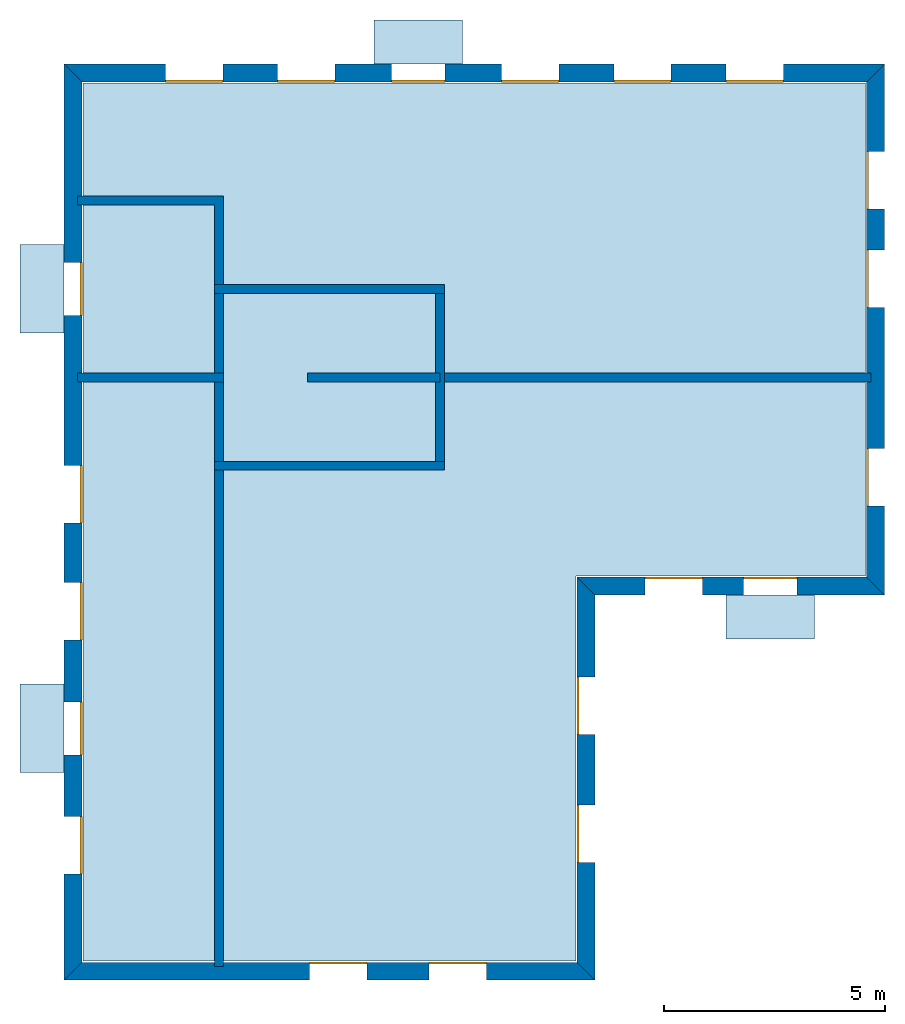
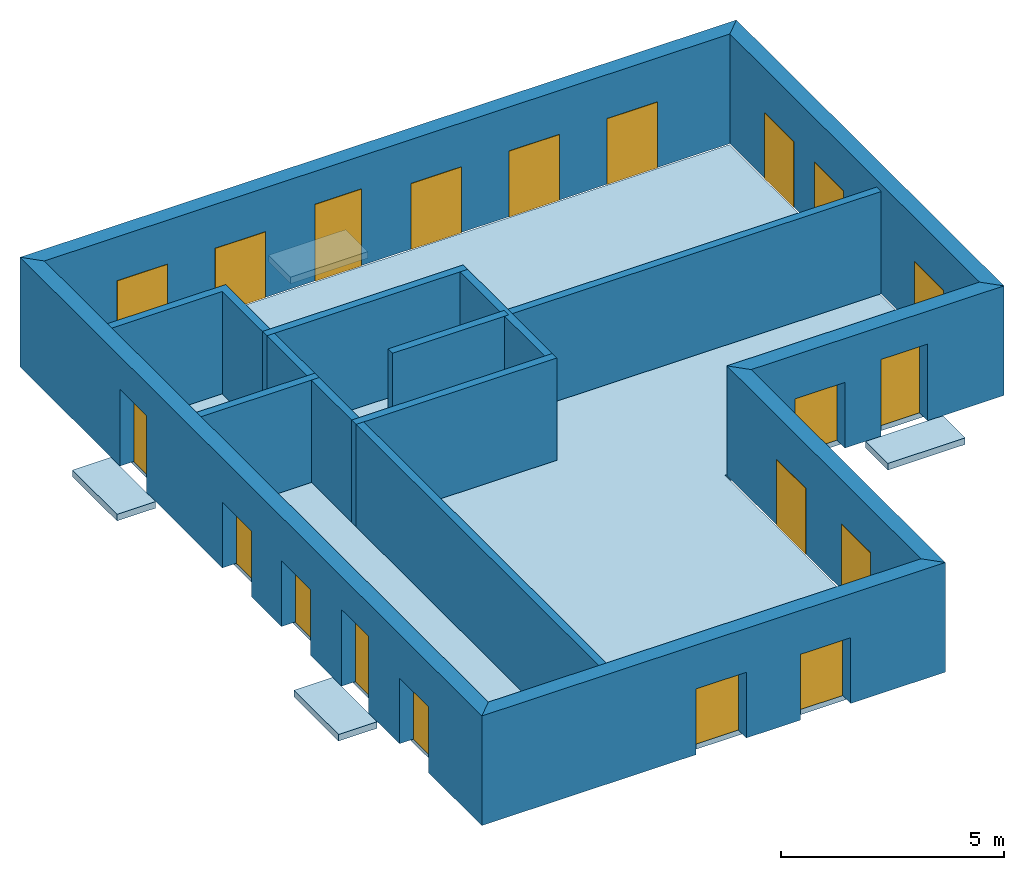
# One storey: 20 windows, 15 walls, 5 slabs, 20 openings.
"""IFC4 building model written with IfcOpenShell, lengths in metres."""

from ifc_helpers import new_model, si_unit, frame, origin_with_axes, place, context, subcontext, project, spatial, line, indexed_curve, outline, extrude, element, fill, save


model = new_model("IFC4")

# Units and contexts
model_context = context("Model", 3, precision=1e-05, world=origin_with_axes())
body_context = subcontext(model_context, "Body", "Model", "MODEL_VIEW")
ifc_project = project(units=[si_unit("VOLUMEUNIT", "CUBIC_METRE"), si_unit("LENGTHUNIT", "METRE"), si_unit("AREAUNIT", "SQUARE_METRE")], contexts=[model_context])

# Site, building, storey
site = spatial("IfcSite", under=ifc_project)
building = spatial("IfcBuilding", under=site, Name="Building 1")
storey_placement = place(None, frame((0.0, 0.0, 4.0), z_axis=(0.0, 0.0, 1.0), x_axis=(1.0, 0.0, 0.0)))
storey = spatial("IfcBuildingStorey", under=building, at=storey_placement, Name="02 Storey")

# Slabs
slab_1_placement = place(storey_placement, origin_with_axes())
element("IfcSlab", 1, at=slab_1_placement, inside=storey, Name="Slab", context=body_context, shape_type="SweptSolid", body=[
    extrude(outline(indexed_curve([(15.563354, 14.685575), (22.109464, 14.685575), (22.109464, 25.825575), (4.423354, 25.825575), (4.423354, 5.9782), (15.563354, 5.9782)], segments=[line(1, 2), line(2, 3), line(3, 4), line(4, 5), line(5, 6)])), origin_with_axes(), (0.0, 0.0, -1.0), 0.2),
])
slab_2_placement = place(storey_placement, origin_with_axes())
element("IfcSlab", 2, at=slab_2_placement, inside=storey, Name="Balcony", context=body_context, shape_type="SweptSolid", body=[
    extrude(outline(indexed_curve([(20.9574273333333, 14.255575), (20.9574273333333, 13.255575), (18.9574273333333, 13.255575), (18.9574273333333, 14.255575)], segments=[line(1, 2), line(2, 3), line(3, 4)])), origin_with_axes(), (0.0, 0.0, -1.0), 0.18),
])
slab_3_placement = place(storey_placement, origin_with_axes())
element("IfcSlab", 3, at=slab_3_placement, inside=storey, Name="Balcony", context=body_context, shape_type="SweptSolid", body=[
    extrude(outline(indexed_curve([(10.9988297142857, 26.255575), (10.9988297142857, 27.255575), (12.9988297142857, 27.255575), (12.9988297142857, 26.255575)], segments=[line(1, 2), line(2, 3), line(3, 4)])), origin_with_axes(), (0.0, 0.0, -1.0), 0.18),
])
slab_4_placement = place(storey_placement, origin_with_axes())
element("IfcSlab", 4, at=slab_4_placement, inside=storey, Name="Balcony", context=body_context, shape_type="SweptSolid", body=[
    extrude(outline(indexed_curve([(3.993354, 10.2388972), (2.993354, 10.2388972), (2.993354, 12.2388972), (3.993354, 12.2388972)], segments=[line(1, 2), line(2, 3), line(3, 4)])), origin_with_axes(), (0.0, 0.0, -1.0), 0.18),
])
slab_5_placement = place(storey_placement, origin_with_axes())
element("IfcSlab", 5, at=slab_5_placement, inside=storey, Name="Balcony", context=body_context, shape_type="SweptSolid", body=[
    extrude(outline(indexed_curve([(3.993354, 20.174943), (2.993354, 20.174943), (2.993354, 22.174943), (3.993354, 22.174943)], segments=[line(1, 2), line(2, 3), line(3, 4)])), origin_with_axes(), (0.0, 0.0, -1.0), 0.18),
])

# Walls
wall_1_placement = place(storey_placement, origin_with_axes())
element("IfcWall", 6, at=wall_1_placement, inside=storey, Name="Wall", context=body_context, shape_type="SweptSolid", body=[
    extrude(outline(indexed_curve([(22.239464, 19.274943), (12.393354, 19.274943), (12.393354, 19.074943), (22.239464, 19.074943)], segments=[line(1, 2), line(2, 3), line(3, 4)])), origin_with_axes(), (0.0, 0.0, 1.0), 2.8),
])
wall_2_placement = place(storey_placement, origin_with_axes())
element("IfcWall", 7, at=wall_2_placement, inside=storey, Name="Wall", context=body_context, shape_type="SweptSolid", body=[
    extrude(outline(indexed_curve([(7.593354, 17.274943), (7.393354, 17.274943), (7.393354, 5.8482), (7.593354, 5.8482)], segments=[line(1, 2), line(2, 3), line(3, 4)])), origin_with_axes(), (0.0, 0.0, 1.0), 2.8),
])
wall_3_placement = place(storey_placement, origin_with_axes())
element("IfcWall", 8, at=wall_3_placement, inside=storey, Name="Wall", context=body_context, shape_type="SweptSolid", body=[
    extrude(outline(indexed_curve([(7.593354, 19.274943), (4.293354, 19.274943), (4.293354, 19.074943), (7.593354, 19.074943)], segments=[line(1, 2), line(2, 3), line(3, 4)])), origin_with_axes(), (0.0, 0.0, 1.0), 2.8),
])
wall_4_placement = place(storey_placement, origin_with_axes())
element("IfcWall", 9, at=wall_4_placement, inside=storey, Name="Wall", context=body_context, shape_type="SweptSolid", body=[
    extrude(outline(indexed_curve([(7.593354, 23.274943), (4.293354, 23.274943), (4.293354, 23.074943), (7.393354, 23.074943), (7.393354, 21.074943), (7.593354, 21.074943)], segments=[line(1, 2), line(2, 3), line(3, 4), line(4, 5), line(5, 6)])), origin_with_axes(), (0.0, 0.0, 1.0), 2.8),
])

# Wall, openings, windows
wall_5_placement = place(storey_placement, origin_with_axes())
wall_5 = element("IfcWall", 10, at=wall_5_placement, inside=storey, Name="Facade", context=body_context, shape_type="SweptSolid", body=[
    extrude(outline(indexed_curve([(15.593354, 14.655575), (22.139464, 14.655575), (22.539464, 14.255575), (15.993354, 14.255575)], segments=[line(1, 2), line(2, 3), line(3, 4)])), origin_with_axes(), (0.0, 0.0, 1.0), 3.0),
])
opening_1_placement = place(wall_5_placement, origin_with_axes())
opening_1 = element("IfcOpeningElement", 11, at=opening_1_placement, cuts=wall_5, Name="Opening", context=body_context, shape_type="SweptSolid", body=[
    extrude(outline(indexed_curve([(17.1253906666667, 14.215575), (17.1253906666667, 14.715575), (18.4253906666667, 14.715575), (18.4253906666667, 14.215575)], segments=[line(1, 2), line(2, 3), line(3, 4)])), origin_with_axes(), (0.0, 0.0, 1.0), 1.8),
])
opening_2_placement = place(wall_5_placement, origin_with_axes())
opening_2 = element("IfcOpeningElement", 12, at=opening_2_placement, cuts=wall_5, Name="Opening", context=body_context, shape_type="SweptSolid", body=[
    extrude(outline(indexed_curve([(19.3574273333333, 14.215575), (19.3574273333333, 14.715575), (20.5574273333333, 14.715575), (20.5574273333333, 14.215575)], segments=[line(1, 2), line(2, 3), line(3, 4)])), origin_with_axes(), (0.0, 0.0, 1.0), 2.1),
])
window_1_placement = place(storey_placement, origin_with_axes())
window_1 = element("IfcWindow", 13, at=window_1_placement, inside=storey, Name="Window", PredefinedType="WINDOW", context=body_context, shape_type="SweptSolid", body=[
    extrude(outline(indexed_curve([(17.1253906666667, 14.615575), (17.1253906666667, 14.665575), (18.4253906666667, 14.665575), (18.4253906666667, 14.615575)], segments=[line(1, 2), line(2, 3), line(3, 4)])), origin_with_axes(), (0.0, 0.0, 1.0), 1.8),
])
fill(opening_1, window_1)
window_2_placement = place(storey_placement, origin_with_axes())
window_2 = element("IfcWindow", 14, at=window_2_placement, inside=storey, Name="Window", PredefinedType="WINDOW", context=body_context, shape_type="SweptSolid", body=[
    extrude(outline(indexed_curve([(19.3574273333333, 14.615575), (19.3574273333333, 14.665575), (20.5574273333333, 14.665575), (20.5574273333333, 14.615575)], segments=[line(1, 2), line(2, 3), line(3, 4)])), origin_with_axes(), (0.0, 0.0, 1.0), 2.1),
])
fill(opening_2, window_2)

wall_6_placement = place(storey_placement, origin_with_axes())
wall_6 = element("IfcWall", 15, at=wall_6_placement, inside=storey, Name="Facade", context=body_context, shape_type="SweptSolid", body=[
    extrude(outline(indexed_curve([(22.139464, 14.655575), (22.139464, 25.855575), (22.539464, 26.255575), (22.539464, 14.255575)], segments=[line(1, 2), line(2, 3), line(3, 4)])), origin_with_axes(), (0.0, 0.0, 1.0), 3.0),
])
opening_3_placement = place(wall_6_placement, origin_with_axes())
opening_3 = element("IfcOpeningElement", 16, at=opening_3_placement, cuts=wall_6, Name="Opening", context=body_context, shape_type="SweptSolid", body=[
    extrude(outline(indexed_curve([(22.579464, 16.265259), (22.079464, 16.265259), (22.079464, 17.565259), (22.579464, 17.565259)], segments=[line(1, 2), line(2, 3), line(3, 4)])), origin_with_axes(), (0.0, 0.0, 1.0), 1.8),
])
opening_4_placement = place(wall_6_placement, origin_with_axes())
opening_4 = element("IfcOpeningElement", 17, at=opening_4_placement, cuts=wall_6, Name="Opening", context=body_context, shape_type="SweptSolid", body=[
    extrude(outline(indexed_curve([(22.579464, 20.7518203333333), (22.079464, 20.7518203333333), (22.079464, 22.0518203333333), (22.579464, 22.0518203333333)], segments=[line(1, 2), line(2, 3), line(3, 4)])), origin_with_axes(), (0.0, 0.0, 1.0), 1.8),
])
opening_5_placement = place(wall_6_placement, origin_with_axes())
opening_5 = element("IfcOpeningElement", 18, at=opening_5_placement, cuts=wall_6, Name="Opening", context=body_context, shape_type="SweptSolid", body=[
    extrude(outline(indexed_curve([(22.579464, 22.9786976666667), (22.079464, 22.9786976666667), (22.079464, 24.2786976666667), (22.579464, 24.2786976666667)], segments=[line(1, 2), line(2, 3), line(3, 4)])), origin_with_axes(), (0.0, 0.0, 1.0), 1.8),
])
window_3_placement = place(storey_placement, origin_with_axes())
window_3 = element("IfcWindow", 19, at=window_3_placement, inside=storey, Name="Window", PredefinedType="WINDOW", context=body_context, shape_type="SweptSolid", body=[
    extrude(outline(indexed_curve([(22.179464, 16.265259), (22.129464, 16.265259), (22.129464, 17.565259), (22.179464, 17.565259)], segments=[line(1, 2), line(2, 3), line(3, 4)])), origin_with_axes(), (0.0, 0.0, 1.0), 1.8),
])
fill(opening_3, window_3)
window_4_placement = place(storey_placement, origin_with_axes())
window_4 = element("IfcWindow", 20, at=window_4_placement, inside=storey, Name="Window", PredefinedType="WINDOW", context=body_context, shape_type="SweptSolid", body=[
    extrude(outline(indexed_curve([(22.179464, 20.7518203333333), (22.129464, 20.7518203333333), (22.129464, 22.0518203333333), (22.179464, 22.0518203333333)], segments=[line(1, 2), line(2, 3), line(3, 4)])), origin_with_axes(), (0.0, 0.0, 1.0), 1.8),
])
fill(opening_4, window_4)
window_5_placement = place(storey_placement, origin_with_axes())
window_5 = element("IfcWindow", 21, at=window_5_placement, inside=storey, Name="Window", PredefinedType="WINDOW", context=body_context, shape_type="SweptSolid", body=[
    extrude(outline(indexed_curve([(22.179464, 22.9786976666667), (22.129464, 22.9786976666667), (22.129464, 24.2786976666667), (22.179464, 24.2786976666667)], segments=[line(1, 2), line(2, 3), line(3, 4)])), origin_with_axes(), (0.0, 0.0, 1.0), 1.8),
])
fill(opening_5, window_5)

wall_7_placement = place(storey_placement, origin_with_axes())
wall_7 = element("IfcWall", 22, at=wall_7_placement, inside=storey, Name="Facade", context=body_context, shape_type="SweptSolid", body=[
    extrude(outline(indexed_curve([(22.139464, 25.855575), (4.393354, 25.855575), (3.993354, 26.255575), (22.539464, 26.255575)], segments=[line(1, 2), line(2, 3), line(3, 4)])), origin_with_axes(), (0.0, 0.0, 1.0), 3.0),
])
opening_6_placement = place(wall_7_placement, origin_with_axes())
opening_6 = element("IfcOpeningElement", 23, at=opening_6_placement, cuts=wall_7, Name="Opening", context=body_context, shape_type="SweptSolid", body=[
    extrude(outline(indexed_curve([(20.2543054285714, 26.295575), (20.2543054285714, 25.795575), (18.9543054285714, 25.795575), (18.9543054285714, 26.295575)], segments=[line(1, 2), line(2, 3), line(3, 4)])), origin_with_axes(), (0.0, 0.0, 1.0), 1.8),
])
opening_7_placement = place(wall_7_placement, origin_with_axes())
opening_7 = element("IfcOpeningElement", 24, at=opening_7_placement, cuts=wall_7, Name="Opening", context=body_context, shape_type="SweptSolid", body=[
    extrude(outline(indexed_curve([(17.7191468571429, 26.295575), (17.7191468571429, 25.795575), (16.4191468571429, 25.795575), (16.4191468571429, 26.295575)], segments=[line(1, 2), line(2, 3), line(3, 4)])), origin_with_axes(), (0.0, 0.0, 1.0), 1.8),
])
opening_8_placement = place(wall_7_placement, origin_with_axes())
opening_8 = element("IfcOpeningElement", 25, at=opening_8_placement, cuts=wall_7, Name="Opening", context=body_context, shape_type="SweptSolid", body=[
    extrude(outline(indexed_curve([(15.1839882857143, 26.295575), (15.1839882857143, 25.795575), (13.8839882857143, 25.795575), (13.8839882857143, 26.295575)], segments=[line(1, 2), line(2, 3), line(3, 4)])), origin_with_axes(), (0.0, 0.0, 1.0), 1.8),
])
opening_9_placement = place(wall_7_placement, origin_with_axes())
opening_9 = element("IfcOpeningElement", 26, at=opening_9_placement, cuts=wall_7, Name="Opening", context=body_context, shape_type="SweptSolid", body=[
    extrude(outline(indexed_curve([(12.5988297142857, 26.295575), (12.5988297142857, 25.795575), (11.3988297142857, 25.795575), (11.3988297142857, 26.295575)], segments=[line(1, 2), line(2, 3), line(3, 4)])), origin_with_axes(), (0.0, 0.0, 1.0), 2.1),
])
opening_10_placement = place(wall_7_placement, origin_with_axes())
opening_10 = element("IfcOpeningElement", 27, at=opening_10_placement, cuts=wall_7, Name="Opening", context=body_context, shape_type="SweptSolid", body=[
    extrude(outline(indexed_curve([(10.1136711428571, 26.295575), (10.1136711428571, 25.795575), (8.81367114285714, 25.795575), (8.81367114285714, 26.295575)], segments=[line(1, 2), line(2, 3), line(3, 4)])), origin_with_axes(), (0.0, 0.0, 1.0), 1.8),
])
opening_11_placement = place(wall_7_placement, origin_with_axes())
opening_11 = element("IfcOpeningElement", 28, at=opening_11_placement, cuts=wall_7, Name="Opening", context=body_context, shape_type="SweptSolid", body=[
    extrude(outline(indexed_curve([(7.57851257142857, 26.295575), (7.57851257142857, 25.795575), (6.27851257142857, 25.795575), (6.27851257142857, 26.295575)], segments=[line(1, 2), line(2, 3), line(3, 4)])), origin_with_axes(), (0.0, 0.0, 1.0), 1.8),
])
window_6_placement = place(storey_placement, origin_with_axes())
window_6 = element("IfcWindow", 29, at=window_6_placement, inside=storey, Name="Window", PredefinedType="WINDOW", context=body_context, shape_type="SweptSolid", body=[
    extrude(outline(indexed_curve([(20.2543054285714, 25.895575), (20.2543054285714, 25.845575), (18.9543054285714, 25.845575), (18.9543054285714, 25.895575)], segments=[line(1, 2), line(2, 3), line(3, 4)])), origin_with_axes(), (0.0, 0.0, 1.0), 1.8),
])
fill(opening_6, window_6)
window_7_placement = place(storey_placement, origin_with_axes())
window_7 = element("IfcWindow", 30, at=window_7_placement, inside=storey, Name="Window", PredefinedType="WINDOW", context=body_context, shape_type="SweptSolid", body=[
    extrude(outline(indexed_curve([(17.7191468571429, 25.895575), (17.7191468571429, 25.845575), (16.4191468571429, 25.845575), (16.4191468571429, 25.895575)], segments=[line(1, 2), line(2, 3), line(3, 4)])), origin_with_axes(), (0.0, 0.0, 1.0), 1.8),
])
fill(opening_7, window_7)
window_8_placement = place(storey_placement, origin_with_axes())
window_8 = element("IfcWindow", 31, at=window_8_placement, inside=storey, Name="Window", PredefinedType="WINDOW", context=body_context, shape_type="SweptSolid", body=[
    extrude(outline(indexed_curve([(15.1839882857143, 25.895575), (15.1839882857143, 25.845575), (13.8839882857143, 25.845575), (13.8839882857143, 25.895575)], segments=[line(1, 2), line(2, 3), line(3, 4)])), origin_with_axes(), (0.0, 0.0, 1.0), 1.8),
])
fill(opening_8, window_8)
window_9_placement = place(storey_placement, origin_with_axes())
window_9 = element("IfcWindow", 32, at=window_9_placement, inside=storey, Name="Window", PredefinedType="WINDOW", context=body_context, shape_type="SweptSolid", body=[
    extrude(outline(indexed_curve([(12.5988297142857, 25.895575), (12.5988297142857, 25.845575), (11.3988297142857, 25.845575), (11.3988297142857, 25.895575)], segments=[line(1, 2), line(2, 3), line(3, 4)])), origin_with_axes(), (0.0, 0.0, 1.0), 2.1),
])
fill(opening_9, window_9)
window_10_placement = place(storey_placement, origin_with_axes())
window_10 = element("IfcWindow", 33, at=window_10_placement, inside=storey, Name="Window", PredefinedType="WINDOW", context=body_context, shape_type="SweptSolid", body=[
    extrude(outline(indexed_curve([(10.1136711428571, 25.895575), (10.1136711428571, 25.845575), (8.81367114285714, 25.845575), (8.81367114285714, 25.895575)], segments=[line(1, 2), line(2, 3), line(3, 4)])), origin_with_axes(), (0.0, 0.0, 1.0), 1.8),
])
fill(opening_10, window_10)
window_11_placement = place(storey_placement, origin_with_axes())
window_11 = element("IfcWindow", 34, at=window_11_placement, inside=storey, Name="Window", PredefinedType="WINDOW", context=body_context, shape_type="SweptSolid", body=[
    extrude(outline(indexed_curve([(7.57851257142857, 25.895575), (7.57851257142857, 25.845575), (6.27851257142857, 25.845575), (6.27851257142857, 25.895575)], segments=[line(1, 2), line(2, 3), line(3, 4)])), origin_with_axes(), (0.0, 0.0, 1.0), 1.8),
])
fill(opening_11, window_11)

wall_8_placement = place(storey_placement, origin_with_axes())
wall_8 = element("IfcWall", 35, at=wall_8_placement, inside=storey, Name="Facade", context=body_context, shape_type="SweptSolid", body=[
    extrude(outline(indexed_curve([(4.393354, 25.855575), (4.393354, 5.9482), (3.993354, 5.5482), (3.993354, 26.255575)], segments=[line(1, 2), line(2, 3), line(3, 4)])), origin_with_axes(), (0.0, 0.0, 1.0), 3.0),
])
opening_12_placement = place(wall_8_placement, origin_with_axes())
opening_12 = element("IfcOpeningElement", 36, at=opening_12_placement, cuts=wall_8, Name="Opening", context=body_context, shape_type="SweptSolid", body=[
    extrude(outline(indexed_curve([(3.953354, 17.1795944), (4.453354, 17.1795944), (4.453354, 15.8795944), (3.953354, 15.8795944)], segments=[line(1, 2), line(2, 3), line(3, 4)])), origin_with_axes(), (0.0, 0.0, 1.0), 1.8),
])
opening_13_placement = place(wall_8_placement, origin_with_axes())
opening_13 = element("IfcOpeningElement", 37, at=opening_13_placement, cuts=wall_8, Name="Opening", context=body_context, shape_type="SweptSolid", body=[
    extrude(outline(indexed_curve([(3.953354, 14.5342458), (4.453354, 14.5342458), (4.453354, 13.2342458), (3.953354, 13.2342458)], segments=[line(1, 2), line(2, 3), line(3, 4)])), origin_with_axes(), (0.0, 0.0, 1.0), 1.8),
])
opening_14_placement = place(wall_8_placement, origin_with_axes())
opening_14 = element("IfcOpeningElement", 38, at=opening_14_placement, cuts=wall_8, Name="Opening", context=body_context, shape_type="SweptSolid", body=[
    extrude(outline(indexed_curve([(3.953354, 11.8388972), (4.453354, 11.8388972), (4.453354, 10.6388972), (3.953354, 10.6388972)], segments=[line(1, 2), line(2, 3), line(3, 4)])), origin_with_axes(), (0.0, 0.0, 1.0), 2.1),
])
opening_15_placement = place(wall_8_placement, origin_with_axes())
opening_15 = element("IfcOpeningElement", 39, at=opening_15_placement, cuts=wall_8, Name="Opening", context=body_context, shape_type="SweptSolid", body=[
    extrude(outline(indexed_curve([(3.953354, 9.2435486), (4.453354, 9.2435486), (4.453354, 7.9435486), (3.953354, 7.9435486)], segments=[line(1, 2), line(2, 3), line(3, 4)])), origin_with_axes(), (0.0, 0.0, 1.0), 1.8),
])
opening_16_placement = place(wall_8_placement, origin_with_axes())
opening_16 = element("IfcOpeningElement", 40, at=opening_16_placement, cuts=wall_8, Name="Opening", context=body_context, shape_type="SweptSolid", body=[
    extrude(outline(indexed_curve([(3.953354, 21.774943), (4.453354, 21.774943), (4.453354, 20.574943), (3.953354, 20.574943)], segments=[line(1, 2), line(2, 3), line(3, 4)])), origin_with_axes(), (0.0, 0.0, 1.0), 2.1),
])
window_12_placement = place(storey_placement, origin_with_axes())
window_12 = element("IfcWindow", 41, at=window_12_placement, inside=storey, Name="Window", PredefinedType="WINDOW", context=body_context, shape_type="SweptSolid", body=[
    extrude(outline(indexed_curve([(4.353354, 17.1795944), (4.403354, 17.1795944), (4.403354, 15.8795944), (4.353354, 15.8795944)], segments=[line(1, 2), line(2, 3), line(3, 4)])), origin_with_axes(), (0.0, 0.0, 1.0), 1.8),
])
fill(opening_12, window_12)
window_13_placement = place(storey_placement, origin_with_axes())
window_13 = element("IfcWindow", 42, at=window_13_placement, inside=storey, Name="Window", PredefinedType="WINDOW", context=body_context, shape_type="SweptSolid", body=[
    extrude(outline(indexed_curve([(4.353354, 14.5342458), (4.403354, 14.5342458), (4.403354, 13.2342458), (4.353354, 13.2342458)], segments=[line(1, 2), line(2, 3), line(3, 4)])), origin_with_axes(), (0.0, 0.0, 1.0), 1.8),
])
fill(opening_13, window_13)
window_14_placement = place(storey_placement, origin_with_axes())
window_14 = element("IfcWindow", 43, at=window_14_placement, inside=storey, Name="Window", PredefinedType="WINDOW", context=body_context, shape_type="SweptSolid", body=[
    extrude(outline(indexed_curve([(4.353354, 11.8388972), (4.403354, 11.8388972), (4.403354, 10.6388972), (4.353354, 10.6388972)], segments=[line(1, 2), line(2, 3), line(3, 4)])), origin_with_axes(), (0.0, 0.0, 1.0), 2.1),
])
fill(opening_14, window_14)
window_15_placement = place(storey_placement, origin_with_axes())
window_15 = element("IfcWindow", 44, at=window_15_placement, inside=storey, Name="Window", PredefinedType="WINDOW", context=body_context, shape_type="SweptSolid", body=[
    extrude(outline(indexed_curve([(4.353354, 9.2435486), (4.403354, 9.2435486), (4.403354, 7.9435486), (4.353354, 7.9435486)], segments=[line(1, 2), line(2, 3), line(3, 4)])), origin_with_axes(), (0.0, 0.0, 1.0), 1.8),
])
fill(opening_15, window_15)
window_16_placement = place(storey_placement, origin_with_axes())
window_16 = element("IfcWindow", 45, at=window_16_placement, inside=storey, Name="Window", PredefinedType="WINDOW", context=body_context, shape_type="SweptSolid", body=[
    extrude(outline(indexed_curve([(4.353354, 21.774943), (4.403354, 21.774943), (4.403354, 20.574943), (4.353354, 20.574943)], segments=[line(1, 2), line(2, 3), line(3, 4)])), origin_with_axes(), (0.0, 0.0, 1.0), 2.1),
])
fill(opening_16, window_16)

wall_9_placement = place(storey_placement, origin_with_axes())
wall_9 = element("IfcWall", 46, at=wall_9_placement, inside=storey, Name="Facade", context=body_context, shape_type="SweptSolid", body=[
    extrude(outline(indexed_curve([(4.393354, 5.9482), (15.593354, 5.9482), (15.993354, 5.5482), (3.993354, 5.5482)], segments=[line(1, 2), line(2, 3), line(3, 4)])), origin_with_axes(), (0.0, 0.0, 1.0), 3.0),
])
opening_17_placement = place(wall_9_placement, origin_with_axes())
opening_17 = element("IfcOpeningElement", 47, at=opening_17_placement, cuts=wall_9, Name="Opening", context=body_context, shape_type="SweptSolid", body=[
    extrude(outline(indexed_curve([(9.543354, 5.5082), (9.543354, 6.0082), (10.843354, 6.0082), (10.843354, 5.5082)], segments=[line(1, 2), line(2, 3), line(3, 4)])), origin_with_axes(), (0.0, 0.0, 1.0), 1.8),
])
opening_18_placement = place(wall_9_placement, origin_with_axes())
opening_18 = element("IfcOpeningElement", 48, at=opening_18_placement, cuts=wall_9, Name="Opening", context=body_context, shape_type="SweptSolid", body=[
    extrude(outline(indexed_curve([(12.243354, 5.5082), (12.243354, 6.0082), (13.543354, 6.0082), (13.543354, 5.5082)], segments=[line(1, 2), line(2, 3), line(3, 4)])), origin_with_axes(), (0.0, 0.0, 1.0), 1.8),
])
window_17_placement = place(storey_placement, origin_with_axes())
window_17 = element("IfcWindow", 49, at=window_17_placement, inside=storey, Name="Window", PredefinedType="WINDOW", context=body_context, shape_type="SweptSolid", body=[
    extrude(outline(indexed_curve([(9.543354, 5.9082), (9.543354, 5.9582), (10.843354, 5.9582), (10.843354, 5.9082)], segments=[line(1, 2), line(2, 3), line(3, 4)])), origin_with_axes(), (0.0, 0.0, 1.0), 1.8),
])
fill(opening_17, window_17)
window_18_placement = place(storey_placement, origin_with_axes())
window_18 = element("IfcWindow", 50, at=window_18_placement, inside=storey, Name="Window", PredefinedType="WINDOW", context=body_context, shape_type="SweptSolid", body=[
    extrude(outline(indexed_curve([(12.243354, 5.9082), (12.243354, 5.9582), (13.543354, 5.9582), (13.543354, 5.9082)], segments=[line(1, 2), line(2, 3), line(3, 4)])), origin_with_axes(), (0.0, 0.0, 1.0), 1.8),
])
fill(opening_18, window_18)

wall_10_placement = place(storey_placement, origin_with_axes())
wall_10 = element("IfcWall", 51, at=wall_10_placement, inside=storey, Name="Facade", context=body_context, shape_type="SweptSolid", body=[
    extrude(outline(indexed_curve([(15.593354, 5.9482), (15.593354, 14.655575), (15.993354, 14.255575), (15.993354, 5.5482)], segments=[line(1, 2), line(2, 3), line(3, 4)])), origin_with_axes(), (0.0, 0.0, 1.0), 3.0),
])
opening_19_placement = place(wall_10_placement, origin_with_axes())
opening_19 = element("IfcOpeningElement", 52, at=opening_19_placement, cuts=wall_10, Name="Opening", context=body_context, shape_type="SweptSolid", body=[
    extrude(outline(indexed_curve([(16.033354, 8.20065833333333), (15.533354, 8.20065833333333), (15.533354, 9.50065833333333), (16.033354, 9.50065833333333)], segments=[line(1, 2), line(2, 3), line(3, 4)])), origin_with_axes(), (0.0, 0.0, 1.0), 1.8),
])
opening_20_placement = place(wall_10_placement, origin_with_axes())
opening_20 = element("IfcOpeningElement", 53, at=opening_20_placement, cuts=wall_10, Name="Opening", context=body_context, shape_type="SweptSolid", body=[
    extrude(outline(indexed_curve([(16.033354, 11.1031166666667), (15.533354, 11.1031166666667), (15.533354, 12.4031166666667), (16.033354, 12.4031166666667)], segments=[line(1, 2), line(2, 3), line(3, 4)])), origin_with_axes(), (0.0, 0.0, 1.0), 1.8),
])
window_19_placement = place(storey_placement, origin_with_axes())
window_19 = element("IfcWindow", 54, at=window_19_placement, inside=storey, Name="Window", PredefinedType="WINDOW", context=body_context, shape_type="SweptSolid", body=[
    extrude(outline(indexed_curve([(15.633354, 8.20065833333333), (15.583354, 8.20065833333333), (15.583354, 9.50065833333333), (15.633354, 9.50065833333333)], segments=[line(1, 2), line(2, 3), line(3, 4)])), origin_with_axes(), (0.0, 0.0, 1.0), 1.8),
])
fill(opening_19, window_19)
window_20_placement = place(storey_placement, origin_with_axes())
window_20 = element("IfcWindow", 55, at=window_20_placement, inside=storey, Name="Window", PredefinedType="WINDOW", context=body_context, shape_type="SweptSolid", body=[
    extrude(outline(indexed_curve([(15.633354, 11.1031166666667), (15.583354, 11.1031166666667), (15.583354, 12.4031166666667), (15.633354, 12.4031166666667)], segments=[line(1, 2), line(2, 3), line(3, 4)])), origin_with_axes(), (0.0, 0.0, 1.0), 1.8),
])
fill(opening_20, window_20)

# Walls
wall_11_placement = place(storey_placement, origin_with_axes())
element("IfcWall", 56, at=wall_11_placement, inside=storey, Name="CoreWall", context=body_context, shape_type="SweptSolid", body=[
    extrude(outline(indexed_curve([(12.593354, 21.274943), (7.393354, 21.274943), (7.393354, 21.074943), (12.593354, 21.074943)], segments=[line(1, 2), line(2, 3), line(3, 4)])), origin_with_axes(), (0.0, 0.0, 1.0), 2.8),
])
wall_12_placement = place(storey_placement, origin_with_axes())
element("IfcWall", 57, at=wall_12_placement, inside=storey, Name="CoreWall", context=body_context, shape_type="SweptSolid", body=[
    extrude(outline(indexed_curve([(7.393354, 17.074943), (12.593354, 17.074943), (12.593354, 17.274943), (7.393354, 17.274943)], segments=[line(1, 2), line(2, 3), line(3, 4)])), origin_with_axes(), (0.0, 0.0, 1.0), 2.8),
])
wall_13_placement = place(storey_placement, origin_with_axes())
element("IfcWall", 58, at=wall_13_placement, inside=storey, Name="CoreWall", context=body_context, shape_type="SweptSolid", body=[
    extrude(outline(indexed_curve([(7.593354, 17.274943), (7.593354, 21.074943), (7.393354, 21.074943), (7.393354, 17.274943)], segments=[line(1, 2), line(2, 3), line(3, 4)])), origin_with_axes(), (0.0, 0.0, 1.0), 2.8),
])
wall_14_placement = place(storey_placement, origin_with_axes())
element("IfcWall", 59, at=wall_14_placement, inside=storey, Name="CoreWall", context=body_context, shape_type="SweptSolid", body=[
    extrude(outline(indexed_curve([(12.393354, 21.074943), (12.393354, 17.274943), (12.593354, 17.274943), (12.593354, 21.074943)], segments=[line(1, 2), line(2, 3), line(3, 4)])), origin_with_axes(), (0.0, 0.0, 1.0), 2.8),
])
wall_15_placement = place(storey_placement, origin_with_axes())
element("IfcWall", 60, at=wall_15_placement, inside=storey, Name="CoreWall", context=body_context, shape_type="SweptSolid", body=[
    extrude(outline(indexed_curve([(12.493354, 19.274943), (9.493354, 19.274943), (9.493354, 19.074943), (12.493354, 19.074943)], segments=[line(1, 2), line(2, 3), line(3, 4)])), origin_with_axes(), (0.0, 0.0, 1.0), 2.8),
])

save(model, "model.ifc")
